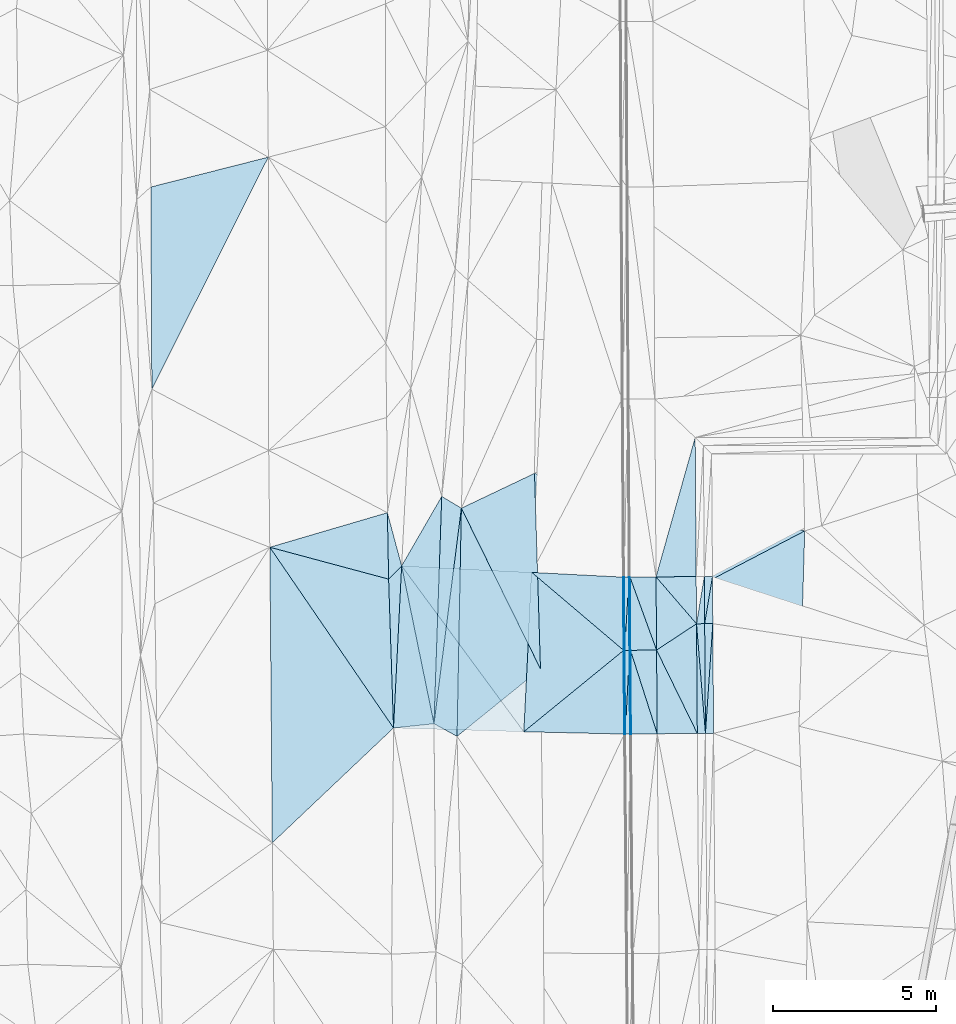
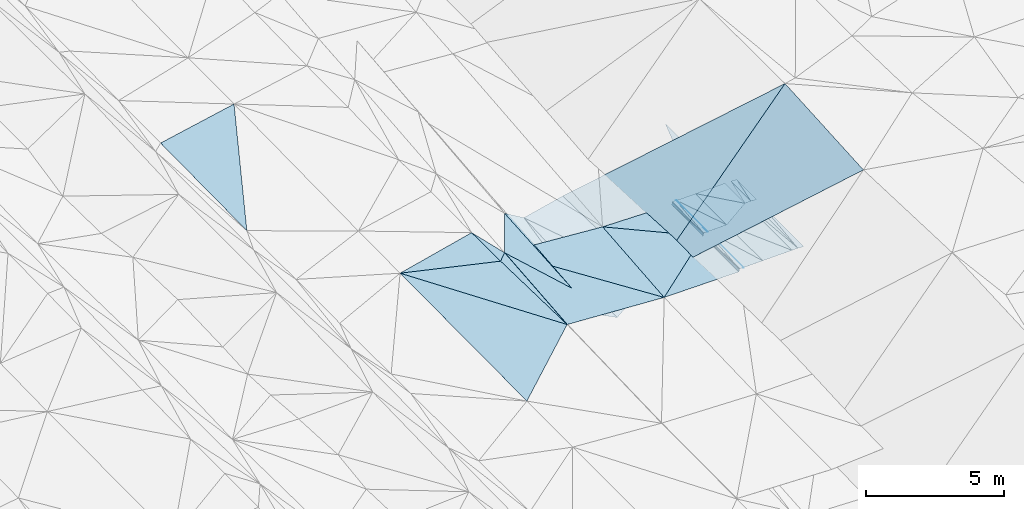
# One storey, part 92 of 275: 47 plates.
"""IFC2X3 building model written with IfcOpenShell, lengths in millimetres."""

from ifc_helpers import new_model, si_unit, frame, origin_with_axes, place, context, subcontext, project, spatial, polyline, outline, extrude, material, type_object, element, save


model = new_model("IFC2X3")

# Units and contexts
model_context = context("Model", 3, precision=1e-05, world=origin_with_axes())
body_context = subcontext(model_context, "Body", "Model", "MODEL_VIEW")
ifc_project = project(units=[si_unit("LENGTHUNIT", "METRE", prefix="MILLI"), si_unit("AREAUNIT", "SQUARE_METRE"), si_unit("VOLUMEUNIT", "CUBIC_METRE"), si_unit("MASSUNIT", "GRAM", prefix="KILO"), si_unit("TIMEUNIT", "SECOND"), si_unit("PLANEANGLEUNIT", "RADIAN"), si_unit("SOLIDANGLEUNIT", "STERADIAN"), si_unit("THERMODYNAMICTEMPERATUREUNIT", "DEGREE_CELSIUS"), si_unit("LUMINOUSINTENSITYUNIT", "LUMEN")], contexts=[model_context])

# Site, building, storey
site_placement = place(None, origin_with_axes())
site = spatial("IfcSite", under=ifc_project, at=site_placement, CompositionType="ELEMENT")
building_placement = place(site_placement, origin_with_axes())
building = spatial("IfcBuilding", under=site, at=building_placement, Name="Undefined", CompositionType="ELEMENT")
storey_placement = place(building_placement, origin_with_axes())
storey = spatial("IfcBuildingStorey", under=building, at=storey_placement, Name="Undefined", CompositionType="ELEMENT", Elevation=0.0)

# Plates
ifc_material = material()
plate_type_1 = type_object("IfcPlateType", PredefinedType="NOTDEFINED")
for number, where, z_axis, x_axis, name in (
    (1, (-54727.6112012956, 41200.2614073738, 42134.4986692953), (-0.0500291336230151, 0.0132224799966271, -0.998660228411881), (0.00717939200595711, -0.999881764103234, -0.0135983140216178), "00_PR"),
    (2, (-54967.2048894094, 39750.0025070273, 42127.2996692371), (-0.0500291336230151, 0.0132224799966271, -0.998660228411881), (-0.00717939200616372, 0.999881764103199, 0.0135983140240582), "00_PR"),
):
    element("IfcPlate", number, at=place(storey_placement, frame(where, z_axis=z_axis, x_axis=x_axis)), inside=storey, type_object=plate_type_1, material=ifc_material, Name=name, context=body_context, shape_type="SweptSolid", body=[
        extrude(outline(polyline([(0.0, 0.0), (1448.63549804688, -7.8580342233181e-10), (1448.46520996094, 250.312698364258), (0.0, 0.0)])), frame((-8.85201319254618e-08, 2.18876761149539e-07, -0.5000001331573), z_axis=(0.0, 0.0, 1.0), x_axis=(1.0, 0.0, 0.0)), (0.0, 0.0, 1.0), 1.0),
    ])
plate_1_placement = place(storey_placement, frame((-54943.0264464103, 36382.3747940596, 42080.155671871), z_axis=(-0.050031720938718, 0.0136211276915439, -0.998654741029311), x_axis=(-0.00717877800396234, 0.999876260767901, 0.0139974390218491)))
element("IfcPlate", 3, at=plate_1_placement, inside=storey, type_object=plate_type_1, material=ifc_material, Name="00_PR", context=body_context, shape_type="SweptSolid", body=[
    extrude(outline(polyline([(0.0, 0.0), (3368.04467773438, -5.30417310073972e-09), (3367.86962890625, 250.312698364258), (0.0, 0.0)])), frame((-8.85201319254618e-08, 2.18876761149539e-07, -0.5000001331573), z_axis=(0.0, 0.0, 1.0), x_axis=(1.0, 0.0, 0.0)), (0.0, 0.0, 1.0), 1.0),
])
plate_2_placement = place(storey_placement, frame((-54977.5702521854, 41198.466930794, 42146.9981456222), z_axis=(0.0198960001570522, 0.013738804213122, -0.999707654485322), x_axis=(0.00717939200595711, -0.999881764103234, -0.0135983140216178)))
element("IfcPlate", 4, at=plate_2_placement, inside=storey, type_object=plate_type_1, material=ifc_material, Name="00_PR", context=body_context, shape_type="SweptSolid", body=[
    extrude(outline(polyline([(0.0, 0.0), (1448.63549804688, -7.8580342233181e-10), (1448.703125, 250.050430297852), (0.0, 0.0)])), frame((-8.85201319254618e-08, 2.18876761149539e-07, -0.5000001331573), z_axis=(0.0, 0.0, 1.0), x_axis=(1.0, 0.0, 0.0)), (0.0, 0.0, 1.0), 1.0),
])
plate_3_placement = place(storey_placement, frame((-54942.9914870141, 36382.3750515832, 42080.1551480393), z_axis=(0.0198930252867533, 0.014137827285837, -0.999702150335077), x_axis=(-0.0811822959986638, 0.996621148703044, 0.0124788130129126)))
element("IfcPlate", 5, at=plate_3_placement, inside=storey, type_object=plate_type_1, material=ifc_material, Name="00_PR", context=body_context, shape_type="SweptSolid", body=[
    extrude(outline(polyline([(0.0, 0.0), (3377.24438476563, 7.02129909768701e-09), (3358.80029296875, 249.369293212891), (0.0, 0.0)])), frame((-8.85201319254618e-08, 2.18876761149539e-07, -0.5000001331573), z_axis=(0.0, 0.0, 1.0), x_axis=(1.0, 0.0, 0.0)), (0.0, 0.0, 1.0), 1.0),
])
plate_4_placement = place(storey_placement, frame((-54717.2108845007, 39751.7974403981, 42114.7996720592), z_axis=(-0.050031720938718, 0.0136211276915439, -0.998654741029311), x_axis=(0.00717877802527681, -0.999876260767883, -0.0139974390122323)))
element("IfcPlate", 6, at=plate_4_placement, inside=storey, type_object=plate_type_1, material=ifc_material, Name="00_PR", context=body_context, shape_type="SweptSolid", body=[
    extrude(outline(polyline([(0.0, 0.0), (3368.04467773438, -5.30417310073972e-09), (3367.86962890625, 250.312698364258), (0.0, 0.0)])), frame((-8.85201319254618e-08, 2.18876761149539e-07, -0.5000001331573), z_axis=(0.0, 0.0, 1.0), x_axis=(1.0, 0.0, 0.0)), (0.0, 0.0, 1.0), 1.0),
])
plate_5_placement = place(storey_placement, frame((-54942.9914870141, 36382.3750515832, 42080.1551480393), z_axis=(0.0198930252867533, 0.014137827285837, -0.999702150335077), x_axis=(-0.999774307000491, -0.00717589897413075, -0.0199960379975748)))
element("IfcPlate", 7, at=plate_5_placement, inside=storey, type_object=plate_type_1, material=ifc_material, Name="00_PR", context=body_context, shape_type="SweptSolid", body=[
    extrude(outline(polyline([(0.0, 0.0), (250.049530029297, -4.94765117764473e-10), (249.114990234375, 3368.04418945313), (0.0, 0.0)])), frame((-8.85201319254618e-08, 2.18876761149539e-07, -0.5000001331573), z_axis=(0.0, 0.0, 1.0), x_axis=(1.0, 0.0, 0.0)), (0.0, 0.0, 1.0), 1.0),
])
plate_type_2 = type_object("IfcPlateType", PredefinedType="NOTDEFINED")
plate_6_placement = place(storey_placement, frame((-64268.6132711576, 41525.3825360347, 42029.5003361414), z_axis=(-0.0323969335024807, 0.0170623473576201, -0.99932943267087), x_axis=(0.998195226832468, -0.050030930024111, -0.0332143819722891)))
element("IfcPlate", 8, at=plate_6_placement, inside=storey, type_object=plate_type_2, material=ifc_material, Name="00_PR", context=body_context, shape_type="SweptSolid", body=[
    extrude(outline(polyline([(0.0, 0.0), (4002.2119140625, -2.02999217435718e-09), (4004.71752929688, 4898.59375), (0.0, 0.0)])), frame((-8.85201319254618e-08, 2.18876761149539e-07, -0.5000001331573), z_axis=(0.0, 0.0, 1.0), x_axis=(1.0, 0.0, 0.0)), (0.0, 0.0, 1.0), 1.0),
])
plate_type_3 = type_object("IfcPlateType", PredefinedType="NOTDEFINED")
plate_7_placement = place(storey_placement, frame((-57469.4531413011, 41180.6696603921, 41981.1387339735), z_axis=(0.97008685411692, 0.0104026312350301, -0.242535112371229), x_axis=(0.242514674953187, 0.0032021420272561, 0.970142452796901)))
element("IfcPlate", 9, at=plate_7_placement, inside=storey, type_object=plate_type_3, material=ifc_material, Name="00_PR", context=body_context, shape_type="SweptSolid", body=[
    extrude(outline(polyline([(0.0, 0.0), (123.693176269531, -2.18278728425503e-11), (90.8259963989258, 2247.98510742188), (0.0, 0.0)])), frame((-8.85201319254618e-08, 2.18876761149539e-07, -0.5000001331573), z_axis=(0.0, 0.0, 1.0), x_axis=(1.0, 0.0, 0.0)), (0.0, 0.0, 1.0), 1.0),
])
plate_8_placement = place(storey_placement, frame((-57422.9939080285, 38933.108525274, 42070.5647368765), z_axis=(0.970087448846926, 0.010402738054017, -0.242532728988568), x_axis=(-0.242505273008574, -0.00384325403053033, -0.970142475083683)))
element("IfcPlate", 10, at=plate_8_placement, inside=storey, type_object=plate_type_3, material=ifc_material, Name="00_PR", context=body_context, shape_type="SweptSolid", body=[
    extrude(outline(polyline([(0.0, 0.0), (123.693176269531, -2.18278728425503e-11), (89.3846206665039, 2248.04296875), (0.0, 0.0)])), frame((-8.85201319254618e-08, 2.18876761149539e-07, -0.5000001331573), z_axis=(0.0, 0.0, 1.0), x_axis=(1.0, 0.0, 0.0)), (0.0, 0.0, 1.0), 1.0),
])
plate_9_placement = place(storey_placement, frame((-57452.9901563924, 38932.6333974839, 41950.5647367324), z_axis=(0.970081668101045, 0.0109155016289847, -0.242533315316642), x_axis=(0.24250527301085, 0.00384325403935343, 0.970142475083079)))
element("IfcPlate", 11, at=plate_9_placement, inside=storey, type_object=plate_type_3, material=ifc_material, Name="00_PR", context=body_context, shape_type="SweptSolid", body=[
    extrude(outline(polyline([(0.0, 0.0), (123.693176269531, -2.18278728425503e-11), (83.4706192016602, 2569.92138671875), (0.0, 0.0)])), frame((-8.85201319254618e-08, 2.18876761149539e-07, -0.5000001331573), z_axis=(0.0, 0.0, 1.0), x_axis=(1.0, 0.0, 0.0)), (0.0, 0.0, 1.0), 1.0),
])
plate_10_placement = place(storey_placement, frame((-57403.1382059913, 36363.2049186787, 42034.3217393355), z_axis=(0.970082901697417, 0.0109156866951293, -0.242528372810882), x_axis=(-0.242505601043034, -0.00338357903830475, -0.970144105200691)))
element("IfcPlate", 12, at=plate_10_placement, inside=storey, type_object=plate_type_3, material=ifc_material, Name="00_PR", context=body_context, shape_type="SweptSolid", body=[
    extrude(outline(polyline([(0.0, 0.0), (123.69295501709, -7.27595761418343e-11), (84.6518707275391, 2569.8828125), (0.0, 0.0)])), frame((-8.85201319254618e-08, 2.18876761149539e-07, -0.5000001331573), z_axis=(0.0, 0.0, 1.0), x_axis=(1.0, 0.0, 0.0)), (0.0, 0.0, 1.0), 1.0),
])
plate_type_4 = type_object("IfcPlateType", PredefinedType="NOTDEFINED")
plate_11_placement = place(storey_placement, frame((-57423.4789904714, 38933.1101235532, 42070.1860496375), z_axis=(-7.94832075545829e-05, 0.0135988822710907, -0.999907527766141), x_axis=(0.0592697860093039, 0.998149758490643, 0.0135702649746451)))
element("IfcPlate", 13, at=plate_11_placement, inside=storey, type_object=plate_type_4, material=ifc_material, Name="00_PR", context=body_context, shape_type="SweptSolid", body=[
    extrude(outline(polyline([(0.0, 0.0), (2253.01416015625, 5.2241375669837e-09), (9.765456199646, 149.682632446289), (0.0, 0.0)])), frame((-8.85201319254618e-08, 2.18876761149539e-07, -0.5000001331573), z_axis=(0.0, 0.0, 1.0), x_axis=(1.0, 0.0, 0.0)), (0.0, 0.0, 1.0), 1.0),
])
plate_12_placement = place(storey_placement, frame((-57403.6232947585, 36363.2065115746, 42033.943053356), z_axis=(-9.49626232522323e-05, 0.0141014582987562, -0.999900564984313), x_axis=(0.0505540069801346, 0.998622093006631, 0.0140786269681243)))
element("IfcPlate", 14, at=plate_12_placement, inside=storey, type_object=plate_type_4, material=ifc_material, Name="00_PR", context=body_context, shape_type="SweptSolid", body=[
    extrude(outline(polyline([(0.0, 0.0), (2574.32788085938, -8.61473381519318e-09), (8.59175300598145, 149.755493164063), (0.0, 0.0)])), frame((-8.85201319254618e-08, 2.18876761149539e-07, -0.5000001331573), z_axis=(0.0, 0.0, 1.0), x_axis=(1.0, 0.0, 0.0)), (0.0, 0.0, 1.0), 1.0),
])
plate_13_placement = place(storey_placement, frame((-57289.9433225857, 41181.955731125, 42100.7600495693), z_axis=(-8.05424452953762e-05, 0.0135989451617295, -0.999907526826058), x_axis=(-0.0592697859715913, -0.998149758492797, -0.0135702649809168)))
element("IfcPlate", 15, at=plate_13_placement, inside=storey, type_object=plate_type_4, material=ifc_material, Name="00_PR", context=body_context, shape_type="SweptSolid", body=[
    extrude(outline(polyline([(0.0, 0.0), (2253.01416015625, 5.2241375669837e-09), (9.77706623077393, 149.68115234375), (0.0, 0.0)])), frame((-8.85201319254618e-08, 2.18876761149539e-07, -0.5000001331573), z_axis=(0.0, 0.0, 1.0), x_axis=(1.0, 0.0, 0.0)), (0.0, 0.0, 1.0), 1.0),
])
plate_14_placement = place(storey_placement, frame((-57273.4807077849, 38933.9870869949, 42070.1860533266), z_axis=(-8.24164369162507e-05, 0.0141008233076175, -0.999900575052129), x_axis=(-0.0505540069429314, -0.998622093008485, -0.0140786269702243)))
element("IfcPlate", 16, at=plate_14_placement, inside=storey, type_object=plate_type_4, material=ifc_material, Name="00_PR", context=body_context, shape_type="SweptSolid", body=[
    extrude(outline(polyline([(0.0, 0.0), (2574.32788085938, -8.61473381519318e-09), (8.45851802825928, 149.762176513672), (0.0, 0.0)])), frame((-8.85201319254618e-08, 2.18876761149539e-07, -0.5000001331573), z_axis=(0.0, 0.0, 1.0), x_axis=(1.0, 0.0, 0.0)), (0.0, 0.0, 1.0), 1.0),
])
plate_type_5 = type_object("IfcPlateType", PredefinedType="NOTDEFINED")
plate_15_placement = place(storey_placement, frame((-57259.934249687, 41182.1700349167, 42101.360147623), z_axis=(0.0198911592629531, 0.013742488769951, -0.999707700173197), x_axis=(0.00732272702465656, -0.999880713048566, -0.0135991669750254)))
element("IfcPlate", 17, at=plate_15_placement, inside=storey, type_object=plate_type_5, material=ifc_material, Name="00_PR", context=body_context, shape_type="SweptSolid", body=[
    extrude(outline(polyline([(0.0, 0.0), (2248.22583007813, 4.82395989820361e-09), (2248.23974609375, 30.0064563751221), (0.0, 0.0)])), frame((-8.85201319254618e-08, 2.18876761149539e-07, -0.5000001331573), z_axis=(0.0, 0.0, 1.0), x_axis=(1.0, 0.0, 0.0)), (0.0, 0.0, 1.0), 1.0),
])
plate_16_placement = place(storey_placement, frame((-57243.4711061757, 38934.2125627001, 42070.7861511969), z_axis=(0.0198871813916911, 0.0142530942139884, -0.999700629849567), x_axis=(0.00772524202325747, -0.999870721016058, -0.014101839968992)))
element("IfcPlate", 18, at=plate_16_placement, inside=storey, type_object=plate_type_5, material=ifc_material, Name="00_PR", context=body_context, shape_type="SweptSolid", body=[
    extrude(outline(polyline([(0.0, 0.0), (2570.09008789063, 7.02857505530119e-09), (0.00207687402144074, 30.0064601898193), (0.0, 0.0)])), frame((-8.85201319254618e-08, 2.18876761149539e-07, -0.5000001331573), z_axis=(0.0, 0.0, 1.0), x_axis=(1.0, 0.0, 0.0)), (0.0, 0.0, 1.0), 1.0),
])
plate_17_placement = place(storey_placement, frame((-57273.4707180557, 38933.986908009, 42070.1861496162), z_axis=(0.0198966238373772, 0.0137424548706555, -0.999707591895751), x_axis=(-0.0073227270210732, 0.999880713048701, 0.0135991669669827)))
element("IfcPlate", 19, at=plate_17_placement, inside=storey, type_object=plate_type_5, material=ifc_material, Name="00_PR", context=body_context, shape_type="SweptSolid", body=[
    extrude(outline(polyline([(0.0, 0.0), (2248.23706054688, 6.8903318606317e-09), (2248.23974609375, 30.0058479309082), (0.0, 0.0)])), frame((-8.85201319254618e-08, 2.18876761149539e-07, -0.5000001331573), z_axis=(0.0, 0.0, 1.0), x_axis=(1.0, 0.0, 0.0)), (0.0, 0.0, 1.0), 1.0),
])
plate_18_placement = place(storey_placement, frame((-57253.6149633284, 36364.2167160175, 42033.9431529742), z_axis=(0.0198814369800898, 0.0142530514490652, -0.999700744717136), x_axis=(-0.00772524201908175, 0.999870721016121, 0.0141018399668066)))
element("IfcPlate", 20, at=plate_18_placement, inside=storey, type_object=plate_type_5, material=ifc_material, Name="00_PR", context=body_context, shape_type="SweptSolid", body=[
    extrude(outline(polyline([(0.0, 0.0), (2570.10278320313, -3.19414539262652e-09), (0.0146644422784448, 30.0053596496582), (0.0, 0.0)])), frame((-8.85201319254618e-08, 2.18876761149539e-07, -0.5000001331573), z_axis=(0.0, 0.0, 1.0), x_axis=(1.0, 0.0, 0.0)), (0.0, 0.0, 1.0), 1.0),
])
plate_type_6 = type_object("IfcPlateType", PredefinedType="NOTDEFINED")
plate_19_placement = place(storey_placement, frame((-60518.8160381597, 36433.2778579186, 41820.9953288426), z_axis=(-0.0315980814093276, 0.0176512458969584, -0.999344782729932), x_axis=(-0.999061680915178, 0.0290719680277935, 0.0321026229758529)))
element("IfcPlate", 21, at=plate_19_placement, inside=storey, type_object=plate_type_6, material=ifc_material, Name="00_PR", context=body_context, shape_type="SweptSolid", body=[
    extrude(outline(polyline([(0.0, 0.0), (4002.94384765625, 9.40781319513917e-09), (3901.00927734375, 4981.5771484375), (0.0, 0.0)])), frame((-8.85201319254618e-08, 2.18876761149539e-07, -0.5000001331573), z_axis=(0.0, 0.0, 1.0), x_axis=(1.0, 0.0, 0.0)), (0.0, 0.0, 1.0), 1.0),
])
plate_type_7 = type_object("IfcPlateType", PredefinedType="NOTDEFINED")
plate_20_placement = place(storey_placement, frame((-55258.2239739732, 45467.0649431578, 42207.8701604175), z_axis=(0.019874614355077, 0.0155630649318791, -0.999681344586445), x_axis=(0.0071787759712046, -0.999855286850536, -0.0154230519867774)))
element("IfcPlate", 22, at=plate_20_placement, inside=storey, type_object=plate_type_7, material=ifc_material, Name="00_PR", context=body_context, shape_type="SweptSolid", body=[
    extrude(outline(polyline([(0.0, 0.0), (4271.00927734375, -1.06738298200071e-08), (4271.33544921875, 1232.66809082031), (0.0, 0.0)])), frame((-8.85201319254618e-08, 2.18876761149539e-07, -0.5000001331573), z_axis=(0.0, 0.0, 1.0), x_axis=(1.0, 0.0, 0.0)), (0.0, 0.0, 1.0), 1.0),
])
plate_21_placement = place(storey_placement, frame((-55227.5633467153, 41196.6726047769, 42141.9981471884), z_axis=(0.0198881613536335, 0.0137387333768726, -0.999707811434507), x_axis=(0.00717939200595711, -0.999881764103234, -0.0135983140216178)))
element("IfcPlate", 23, at=plate_21_placement, inside=storey, type_object=plate_type_7, material=ifc_material, Name="00_PR", context=body_context, shape_type="SweptSolid", body=[
    extrude(outline(polyline([(0.0, 0.0), (1448.63586425781, 2.10275175049901e-09), (0.281110644340515, 1232.66809082031), (0.0, 0.0)])), frame((-8.85201319254618e-08, 2.18876761149539e-07, -0.5000001331573), z_axis=(0.0, 0.0, 1.0), x_axis=(1.0, 0.0, 0.0)), (0.0, 0.0, 1.0), 1.0),
])
plate_type_8 = type_object("IfcPlateType", PredefinedType="NOTDEFINED")
plate_22_placement = place(storey_placement, frame((-55217.1640655211, 39748.208233404, 42122.2991474669), z_axis=(0.0196365263267831, 0.0141360640010786, -0.999707246411856), x_axis=(0.00717877802527681, -0.999876260767883, -0.0139974390122323)))
element("IfcPlate", 24, at=plate_22_placement, inside=storey, type_object=plate_type_8, material=ifc_material, Name="00_PR", context=body_context, shape_type="SweptSolid", body=[
    extrude(outline(polyline([(0.0, 0.0), (3368.04418945313, -9.69885149970651e-09), (799.580017089844, 1232.33911132813), (0.0, 0.0)])), frame((-8.85201319254618e-08, 2.18876761149539e-07, -0.5000001331573), z_axis=(0.0, 0.0, 1.0), x_axis=(1.0, 0.0, 0.0)), (0.0, 0.0, 1.0), 1.0),
])
plate_23_placement = place(storey_placement, frame((-56443.4934244053, 38940.2212823785, 42086.7861477036), z_axis=(0.0198946390856509, 0.0137443260212499, -0.999707605671715), x_axis=(-0.00732247799751014, 0.999880690144333, 0.0136009849815906)))
element("IfcPlate", 25, at=plate_23_placement, inside=storey, type_object=plate_type_8, material=ifc_material, Name="00_PR", context=body_context, shape_type="SweptSolid", body=[
    extrude(outline(polyline([(0.0, 0.0), (2247.92529296875, -7.05767888575792e-10), (799.393615722656, 1232.4599609375), (0.0, 0.0)])), frame((-8.85201319254618e-08, 2.18876761149539e-07, -0.5000001331573), z_axis=(0.0, 0.0, 1.0), x_axis=(1.0, 0.0, 0.0)), (0.0, 0.0, 1.0), 1.0),
])
plate_type_9 = type_object("IfcPlateType", PredefinedType="NOTDEFINED")
plate_24_placement = place(storey_placement, frame((-56459.9538086031, 41187.8784620016, 42117.3601478142), z_axis=(0.0198965652225396, 0.0137443396080785, -0.999707567152056), x_axis=(0.00732247799402418, -0.999880690144289, -0.0136009849866788)))
element("IfcPlate", 26, at=plate_24_placement, inside=storey, type_object=plate_type_9, material=ifc_material, Name="00_PR", context=body_context, shape_type="SweptSolid", body=[
    extrude(outline(polyline([(0.0, 0.0), (2247.92529296875, -7.05767888575792e-10), (0.0675204172730446, 800.160766601563), (0.0, 0.0)])), frame((-8.85201319254618e-08, 2.18876761149539e-07, -0.5000001331573), z_axis=(0.0, 0.0, 1.0), x_axis=(1.0, 0.0, 0.0)), (0.0, 0.0, 1.0), 1.0),
])
plate_25_placement = place(storey_placement, frame((-56443.4934280874, 38940.2215376893, 42086.7861511167), z_axis=(0.0198874942824854, 0.0142549877095741, -0.999700596627092), x_axis=(0.00772531599340957, -0.99987069378671, -0.0141037299777694)))
element("IfcPlate", 27, at=plate_25_placement, inside=storey, type_object=plate_type_9, material=ifc_material, Name="00_PR", context=body_context, shape_type="SweptSolid", body=[
    extrude(outline(polyline([(0.0, 0.0), (2569.74584960938, -2.69210431724787e-10), (0.053775604814291, 800.160217285156), (0.0, 0.0)])), frame((-8.85201319254618e-08, 2.18876761149539e-07, -0.5000001331573), z_axis=(0.0, 0.0, 1.0), x_axis=(1.0, 0.0, 0.0)), (0.0, 0.0, 1.0), 1.0),
])
plate_26_placement = place(storey_placement, frame((-57243.4711040108, 38934.2123075094, 42070.786147737), z_axis=(0.0198911592629531, 0.013742488769951, -0.999707700173197), x_axis=(-0.0073227270210732, 0.999880713048701, 0.0135991669669827)))
element("IfcPlate", 28, at=plate_26_placement, inside=storey, type_object=plate_type_9, material=ifc_material, Name="00_PR", context=body_context, shape_type="SweptSolid", body=[
    extrude(outline(polyline([(0.0, 0.0), (2248.22583007813, 4.82395989820361e-09), (0.367824643850327, 800.16015625), (0.0, 0.0)])), frame((-8.85201319254618e-08, 2.18876761149539e-07, -0.5000001331573), z_axis=(0.0, 0.0, 1.0), x_axis=(1.0, 0.0, 0.0)), (0.0, 0.0, 1.0), 1.0),
])
plate_27_placement = place(storey_placement, frame((-57223.6165404638, 36364.4547083661, 42034.5431512138), z_axis=(0.0198814369800898, 0.0142530514490652, -0.999700744717136), x_axis=(-0.00772524201908175, 0.999870721016121, 0.0141018399668066)))
element("IfcPlate", 29, at=plate_27_placement, inside=storey, type_object=plate_type_9, material=ifc_material, Name="00_PR", context=body_context, shape_type="SweptSolid", body=[
    extrude(outline(polyline([(0.0, 0.0), (2570.09008789063, 7.02857505530119e-09), (0.398189932107925, 800.160339355469), (0.0, 0.0)])), frame((-8.85201319254618e-08, 2.18876761149539e-07, -0.5000001331573), z_axis=(0.0, 0.0, 1.0), x_axis=(1.0, 0.0, 0.0)), (0.0, 0.0, 1.0), 1.0),
])
plate_type_10 = type_object("IfcPlateType", PredefinedType="NOTDEFINED")
plate_28_placement = place(storey_placement, frame((-56423.6413351475, 36370.808094334, 42050.5431510274), z_axis=(0.0198798937438238, 0.0142549311251764, -0.999700748605977), x_axis=(-0.00772531599690344, 0.99987069378674, 0.0141037299737119)))
element("IfcPlate", 30, at=plate_28_placement, inside=storey, type_object=plate_type_10, material=ifc_material, Name="00_PR", context=body_context, shape_type="SweptSolid", body=[
    extrude(outline(polyline([(0.0, 0.0), (2569.74584960938, -2.69210431724787e-10), (0.611338078975677, 1230.94152832031), (0.0, 0.0)])), frame((-8.85201319254618e-08, 2.18876761149539e-07, -0.5000001331573), z_axis=(0.0, 0.0, 1.0), x_axis=(1.0, 0.0, 0.0)), (0.0, 0.0, 1.0), 1.0),
])
plate_type_11 = type_object("IfcPlateType", PredefinedType="NOTDEFINED")
plate_29_placement = place(storey_placement, frame((-62435.4748950566, 43296.9195656566, 41864.5134487003), z_axis=(-0.229253409529589, 0.0232313732687595, -0.973089501287064), x_axis=(-0.018903932454635, -0.999632851578271, -0.0194114240396217)))
element("IfcPlate", 31, at=plate_29_placement, inside=storey, type_object=plate_type_11, material=ifc_material, Name="00", context=body_context, shape_type="SweptSolid", body=[
    extrude(outline(polyline([(0.0, 0.0), (7006.18359375, 2.16823536902666e-09), (6629.474609375, 734.674926757813), (0.0, 0.0)])), frame((-8.85201319254618e-08, 2.18876761149539e-07, -0.5000001331573), z_axis=(0.0, 0.0, 1.0), x_axis=(1.0, 0.0, 0.0)), (0.0, 0.0, 1.0), 1.0),
])
plate_type_12 = type_object("IfcPlateType", PredefinedType="NOTDEFINED")
plate_30_placement = place(storey_placement, frame((-60273.59276744, 41325.1465264262, 41896.5692852879), z_axis=(0.0307238416798116, 0.013817592612708, -0.999432398757827), x_axis=(0.998226156850528, -0.0514393219640626, 0.0299755889900947)))
element("IfcPlate", 32, at=plate_30_placement, inside=storey, type_object=plate_type_12, material=ifc_material, Name="00_PR", context=body_context, shape_type="SweptSolid", body=[
    extrude(outline(polyline([(0.0, 0.0), (2808.65209960938, 4.65661287307739e-10), (2939.80688476563, 2244.47607421875), (0.0, 0.0)])), frame((-8.85201319254618e-08, 2.18876761149539e-07, -0.5000001331573), z_axis=(0.0, 0.0, 1.0), x_axis=(1.0, 0.0, 0.0)), (0.0, 0.0, 1.0), 1.0),
])
plate_type_13 = type_object("IfcPlateType", PredefinedType="NOTDEFINED")
plate_31_placement = place(storey_placement, frame((-57453.4597998018, 38932.6348899331, 41950.1862867527), z_axis=(0.0307909476697965, 0.0138967631385345, -0.999429235872089), x_axis=(-0.774612988154064, -0.631592357158684, -0.0326467909873264)))
element("IfcPlate", 33, at=plate_31_placement, inside=storey, type_object=plate_type_13, material=ifc_material, Name="00_PR", context=body_context, shape_type="SweptSolid", body=[
    extrude(outline(polyline([(0.0, 0.0), (3957.23413085938, 4.19095158576965e-09), (675.169921875, 3636.5205078125), (0.0, 0.0)])), frame((-8.85201319254618e-08, 2.18876761149539e-07, -0.5000001331573), z_axis=(0.0, 0.0, 1.0), x_axis=(1.0, 0.0, 0.0)), (0.0, 0.0, 1.0), 1.0),
])
plate_type_14 = type_object("IfcPlateType", PredefinedType="NOTDEFINED")
plate_32_placement = place(storey_placement, frame((-60518.785021295, 36433.2761995889, 41820.9952845842), z_axis=(0.0304376026662385, 0.0143303641526731, -0.99943393628953), x_axis=(0.774612988155051, 0.631592357157267, 0.0326467909913234)))
element("IfcPlate", 34, at=plate_32_placement, inside=storey, type_object=plate_type_14, material=ifc_material, Name="00_PR", context=body_context, shape_type="SweptSolid", body=[
    extrude(outline(polyline([(0.0, 0.0), (3957.23413085938, 4.19095158576965e-09), (2348.33569335938, 2004.31213378906), (0.0, 0.0)])), frame((-8.85201319254618e-08, 2.18876761149539e-07, -0.5000001331573), z_axis=(0.0, 0.0, 1.0), x_axis=(1.0, 0.0, 0.0)), (0.0, 0.0, 1.0), 1.0),
])
plate_type_15 = type_object("IfcPlateType", PredefinedType="NOTDEFINED")
plate_33_placement = place(storey_placement, frame((-64668.444815577, 41119.0138937379, 42039.500402345), z_axis=(-0.036010427423828, 0.0189376987256424, -0.999171963519659), x_axis=(-0.965060519994922, 0.259003655354585, 0.0396900398096927)))
element("IfcPlate", 35, at=plate_33_placement, inside=storey, type_object=plate_type_15, material=ifc_material, Name="00", context=body_context, shape_type="SweptSolid", body=[
    extrude(outline(polyline([(0.0, 0.0), (3779.28564453125, -1.46828824654222e-08), (565.97998046875, 1959.5322265625), (0.0, 0.0)])), frame((-8.85201319254618e-08, 2.18876761149539e-07, -0.5000001331573), z_axis=(0.0, 0.0, 1.0), x_axis=(1.0, 0.0, 0.0)), (0.0, 0.0, 1.0), 1.0),
])
plate_type_16 = type_object("IfcPlateType", PredefinedType="NOTDEFINED")
plate_34_placement = place(storey_placement, frame((-64268.6070759485, 41525.3848977984, 42029.5002052783), z_axis=(-0.0197911130660591, 0.0217314574263627, -0.999567934460551), x_axis=(0.499790788346535, 0.866100081073513, 0.00893406113722198)))
element("IfcPlate", 36, at=plate_34_placement, inside=storey, type_object=plate_type_16, material=ifc_material, Name="00", context=body_context, shape_type="SweptSolid", body=[
    extrude(outline(polyline([(0.0, 0.0), (2462.48583984375, -2.66300048679113e-09), (-3701.33569335938, 3283.021484375), (0.0, 0.0)])), frame((-8.85201319254618e-08, 2.18876761149539e-07, -0.5000001331573), z_axis=(0.0, 0.0, 1.0), x_axis=(1.0, 0.0, 0.0)), (0.0, 0.0, 1.0), 1.0),
])
plate_type_17 = type_object("IfcPlateType", PredefinedType="NOTDEFINED")
plate_35_placement = place(storey_placement, frame((-64268.6189323358, 41525.3831550162, 42029.5005453973), z_axis=(-0.0435227098174604, 0.0182415482616254, -0.998885889202147), x_axis=(-0.0500521903757113, -0.998617538986197, -0.0160558110273057)))
element("IfcPlate", 37, at=plate_35_placement, inside=storey, type_object=plate_type_17, material=ifc_material, Name="00", context=body_context, shape_type="SweptSolid", body=[
    extrude(outline(polyline([(0.0, 0.0), (4982.61962890625, -5.16592990607023e-09), (425.659606933594, 379.35986328125), (0.0, 0.0)])), frame((-8.85201319254618e-08, 2.18876761149539e-07, -0.5000001331573), z_axis=(0.0, 0.0, 1.0), x_axis=(1.0, 0.0, 0.0)), (0.0, 0.0, 1.0), 1.0),
])
plate_type_18 = type_object("IfcPlateType", PredefinedType="NOTDEFINED")
plate_36_placement = place(storey_placement, frame((-63275.7966941754, 36680.1273952758, 41904.5202161642), z_axis=(-0.279974296484216, 0.0297545170387296, -0.959546279250751), x_axis=(0.0340492994935345, 0.999198465700388, 0.0210492599867545)))
element("IfcPlate", 38, at=plate_36_placement, inside=storey, type_object=plate_type_18, material=ifc_material, Name="00", context=body_context, shape_type="SweptSolid", body=[
    extrude(outline(polyline([(0.0, 0.0), (6983.6181640625, 9.73523128777742e-09), (6639.26123046875, 640.225158691406), (0.0, 0.0)])), frame((-8.85201319254618e-08, 2.18876761149539e-07, -0.5000001331573), z_axis=(0.0, 0.0, 1.0), x_axis=(1.0, 0.0, 0.0)), (0.0, 0.0, 1.0), 1.0),
])
plate_type_19 = type_object("IfcPlateType", PredefinedType="NOTDEFINED")
plate_37_placement = place(storey_placement, frame((-63275.6757383351, 36680.1214972026, 41904.5004350509), z_axis=(-0.0380775462509232, 0.0179722822229495, -0.999113155525042), x_axis=(-0.993885881095834, -0.104378165545472, 0.0360007488216561)))
element("IfcPlate", 39, at=plate_37_placement, inside=storey, type_object=plate_type_19, material=ifc_material, Name="00", context=body_context, shape_type="SweptSolid", body=[
    extrude(outline(polyline([(0.0, 0.0), (1249.97399902344, -1.09139364212751e-09), (485.630096435547, 4923.64501953125), (0.0, 0.0)])), frame((-8.85201319254618e-08, 2.18876761149539e-07, -0.5000001331573), z_axis=(0.0, 0.0, 1.0), x_axis=(1.0, 0.0, 0.0)), (0.0, 0.0, 1.0), 1.0),
])
plate_type_20 = type_object("IfcPlateType", PredefinedType="NOTDEFINED")
plate_38_placement = place(storey_placement, frame((-60190.567337797, 44364.8159710807, 41390.5114294365), z_axis=(-0.212293434560382, 0.0125667109957203, -0.977125158522339), x_axis=(0.0305173045598925, -0.999344343149824, -0.0194827599904453)))
element("IfcPlate", 40, at=plate_38_placement, inside=storey, type_object=plate_type_20, material=ifc_material, Name="00", context=body_context, shape_type="SweptSolid", body=[
    extrude(outline(polyline([(0.0, 0.0), (6005.30908203125, -1.46683305501938e-08), (989.458435058594, 2329.29907226563), (0.0, 0.0)])), frame((-8.85201319254618e-08, 2.18876761149539e-07, -0.5000001331573), z_axis=(0.0, 0.0, 1.0), x_axis=(1.0, 0.0, 0.0)), (0.0, 0.0, 1.0), 1.0),
])
plate_type_21 = type_object("IfcPlateType", PredefinedType="NOTDEFINED")
plate_39_placement = place(storey_placement, frame((-71968.5174883315, 53155.0688516082, 42529.5003229314), z_axis=(-0.0302124035109451, 0.0207722511713429, -0.99932763609107), x_axis=(0.968899810100931, 0.246269773705738, -0.024173467796422)))
element("IfcPlate", 41, at=plate_39_placement, inside=storey, type_object=plate_type_21, material=ifc_material, Name="00", context=body_context, shape_type="SweptSolid", body=[
    extrude(outline(polyline([(0.0, 0.0), (3723.09008789063, -1.78843038156629e-08), (-1493.94714355469, 6025.904296875), (0.0, 0.0)])), frame((-8.85201319254618e-08, 2.18876761149539e-07, -0.5000001331573), z_axis=(0.0, 0.0, 1.0), x_axis=(1.0, 0.0, 0.0)), (0.0, 0.0, 1.0), 1.0),
])
plate_type_22 = type_object("IfcPlateType", PredefinedType="NOTDEFINED")
plate_40_placement = place(storey_placement, frame((-62435.4565997265, 43296.9192966469, 41864.5094922619), z_axis=(-0.192662752077327, 0.0226930719053301, -0.981002593497841), x_axis=(0.43906442542581, -0.892077459622574, -0.10686550593544)))
element("IfcPlate", 42, at=plate_40_placement, inside=storey, type_object=plate_type_22, material=ifc_material, Name="00", context=body_context, shape_type="SweptSolid", body=[
    extrude(outline(polyline([(0.0, 0.0), (5530.31591796875, 9.24046617001295e-10), (6204.14599609375, 3255.02416992188), (0.0, 0.0)])), frame((-8.85201319254618e-08, 2.18876761149539e-07, -0.5000001331573), z_axis=(0.0, 0.0, 1.0), x_axis=(1.0, 0.0, 0.0)), (0.0, 0.0, 1.0), 1.0),
])
plate_type_23 = type_object("IfcPlateType", PredefinedType="NOTDEFINED")
plate_41_placement = place(storey_placement, frame((-64706.0751508056, 43157.9067171766, 42079.5005624774), z_axis=(-0.04407181067626, 0.0187826500539195, -0.99885178458101), x_axis=(0.258718356519827, -0.965500067519866, -0.0295707899592593)))
element("IfcPlate", 43, at=plate_41_placement, inside=storey, type_object=plate_type_23, material=ifc_material, Name="00", context=body_context, shape_type="SweptSolid", body=[
    extrude(outline(polyline([(0.0, 0.0), (1690.85778808594, 3.24507709592581e-09), (1979.46862792969, 491.735443115234), (0.0, 0.0)])), frame((-8.85201319254618e-08, 2.18876761149539e-07, -0.5000001331573), z_axis=(0.0, 0.0, 1.0), x_axis=(1.0, 0.0, 0.0)), (0.0, 0.0, 1.0), 1.0),
])
plate_type_24 = type_object("IfcPlateType", PredefinedType="NOTDEFINED")
plate_42_placement = place(storey_placement, frame((-64518.0062710694, 36549.6517641534, 41949.5004002136), z_axis=(-0.0361305770691313, 0.0184906359713355, -0.999175999402521), x_axis=(-0.564479776555991, 0.824675698696657, 0.03567315290914)))
element("IfcPlate", 44, at=plate_42_placement, inside=storey, type_object=plate_type_24, material=ifc_material, Name="00", context=body_context, shape_type="SweptSolid", body=[
    extrude(outline(polyline([(0.0, 0.0), (6727.74853515625, 3.6015990190208e-09), (3856.37182617188, 2457.27416992188), (0.0, 0.0)])), frame((-8.85201319254618e-08, 2.18876761149539e-07, -0.5000001331573), z_axis=(0.0, 0.0, 1.0), x_axis=(1.0, 0.0, 0.0)), (0.0, 0.0, 1.0), 1.0),
])
plate_type_25 = type_object("IfcPlateType", PredefinedType="NOTDEFINED")
plate_43_placement = place(storey_placement, frame((-68315.68268029, 42097.863542818, 42189.5003691806), z_axis=(-0.0329835988541486, 0.0206475822310098, -0.999242592944597), x_axis=(0.564479776485529, -0.824675698744836, -0.0356731529103304)))
element("IfcPlate", 45, at=plate_43_placement, inside=storey, type_object=plate_type_25, material=ifc_material, Name="00", context=body_context, shape_type="SweptSolid", body=[
    extrude(outline(polyline([(0.0, 0.0), (6727.74853515625, 3.6015990190208e-09), (7532.8173828125, 5063.759765625), (0.0, 0.0)])), frame((-8.85201319254618e-08, 2.18876761149539e-07, -0.5000001331573), z_axis=(0.0, 0.0, 1.0), x_axis=(1.0, 0.0, 0.0)), (0.0, 0.0, 1.0), 1.0),
])
plate_type_26 = type_object("IfcPlateType", PredefinedType="NOTDEFINED")
plate_44_placement = place(storey_placement, frame((-60007.0152066843, 38363.4524641623, 41273.5337941124), z_axis=(0.360258836653701, 0.0291789060260705, -0.932395925589577), x_axis=(-0.0305173045645148, 0.999344343149643, 0.019482759992482)))
element("IfcPlate", 46, at=plate_44_placement, inside=storey, type_object=plate_type_26, material=ifc_material, Name="00", context=body_context, shape_type="SweptSolid", body=[
    extrude(outline(polyline([(0.0, 0.0), (6005.30908203125, -1.46683305501938e-08), (4048.13232421875, 8833.5146484375), (0.0, 0.0)])), frame((-8.85201319254618e-08, 2.18876761149539e-07, -0.5000001331573), z_axis=(0.0, 0.0, 1.0), x_axis=(1.0, 0.0, 0.0)), (0.0, 0.0, 1.0), 1.0),
])
plate_type_27 = type_object("IfcPlateType", PredefinedType="NOTDEFINED")
plate_45_placement = place(storey_placement, frame((-51894.5937722099, 42598.2701688999, 44540.5353952294), z_axis=(0.369473157167245, 0.00905990069286223, -0.929197236507031), x_axis=(-0.0295587914147818, -0.9993318534907, -0.0214970800096175)))
element("IfcPlate", 47, at=plate_45_placement, inside=storey, type_object=plate_type_27, material=ifc_material, Name="00", context=body_context, shape_type="SweptSolid", body=[
    extrude(outline(polyline([(0.0, 0.0), (6000.81494140625, 1.52358552441001e-08), (4542.0224609375, 8590.017578125), (0.0, 0.0)])), frame((-8.85201319254618e-08, 2.18876761149539e-07, -0.5000001331573), z_axis=(0.0, 0.0, 1.0), x_axis=(1.0, 0.0, 0.0)), (0.0, 0.0, 1.0), 1.0),
])

save(model, "model.ifc")
